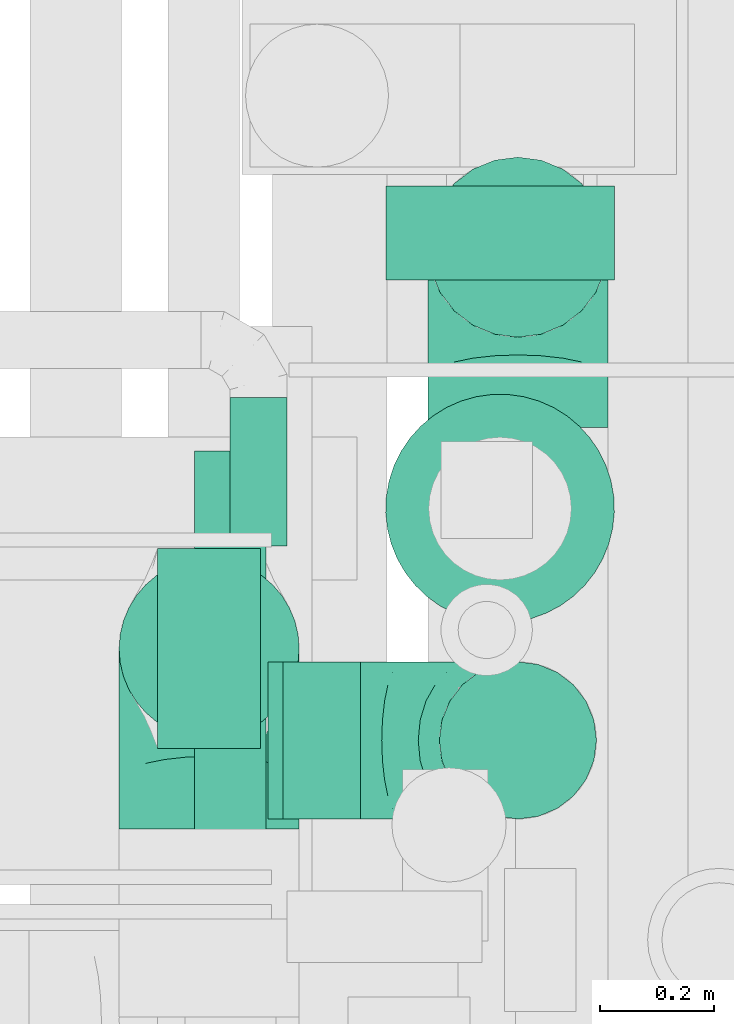
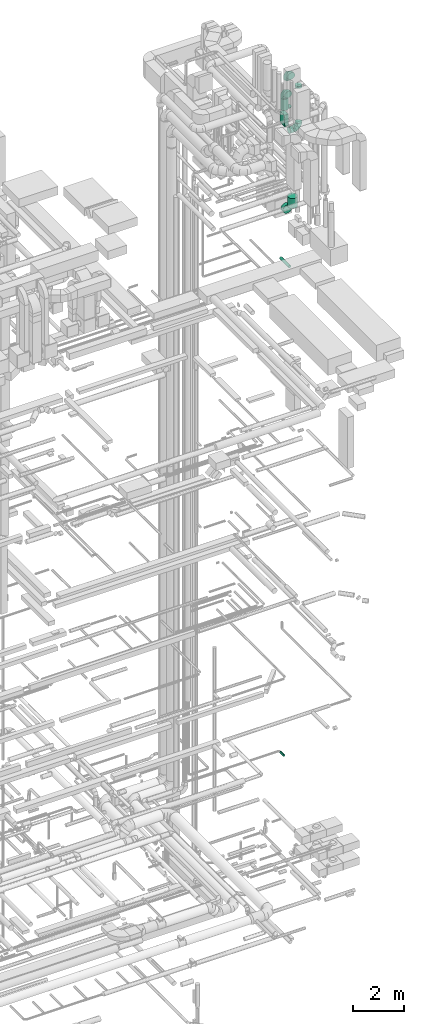
# One storey, part 308 of 337: 7 flow fittings, 7 flow segments.
"""IFC2X3 building model written with IfcOpenShell, lengths in millimetres."""

from ifc_helpers import new_model, entity, si_unit, converted_unit, derived_unit, direction, frame, origin, origin_2d_with_axis, place, context, subcontext, project, spatial, rectangle, circle, extrude, faceted_brep, source, transform, mapped, material, type_object, type_shapes, element, save


model = new_model("IFC2X3")

# Units and contexts
model_context = context("Model", 3, precision=0.01, world=origin(), true_north=direction((6.12303176911189e-17, 1.0)))
body_context = subcontext(model_context, "Body", "Model", "MODEL_VIEW")
ifc_project = project(units=[si_unit("LENGTHUNIT", "METRE", prefix="MILLI"), si_unit("AREAUNIT", "SQUARE_METRE"), si_unit("VOLUMEUNIT", "CUBIC_METRE"), converted_unit("PLANEANGLEUNIT", "DEGREE", entity("IfcRatioMeasure", 0.0174532925199433), si_unit("PLANEANGLEUNIT", "RADIAN"), dimensions=[0, 0, 0, 0, 0, 0, 0]), si_unit("MASSUNIT", "GRAM", prefix="KILO"), derived_unit("MASSDENSITYUNIT", [(si_unit("MASSUNIT", "GRAM", prefix="KILO"), 1), (si_unit("LENGTHUNIT", "METRE"), -3)]), derived_unit("MOMENTOFINERTIAUNIT", [(si_unit("LENGTHUNIT", "METRE"), 4)]), si_unit("TIMEUNIT", "SECOND"), si_unit("FREQUENCYUNIT", "HERTZ"), si_unit("THERMODYNAMICTEMPERATUREUNIT", "DEGREE_CELSIUS"), derived_unit("THERMALTRANSMITTANCEUNIT", [(si_unit("MASSUNIT", "GRAM", prefix="KILO"), 1), (si_unit("THERMODYNAMICTEMPERATUREUNIT", "KELVIN"), -1), (si_unit("TIMEUNIT", "SECOND"), -3)]), derived_unit("VOLUMETRICFLOWRATEUNIT", [(si_unit("LENGTHUNIT", "METRE"), 3), (si_unit("TIMEUNIT", "SECOND"), -1)]), derived_unit("MASSFLOWRATEUNIT", [(si_unit("MASSUNIT", "GRAM", prefix="KILO"), 1), (si_unit("TIMEUNIT", "SECOND"), -1)]), derived_unit("ROTATIONALFREQUENCYUNIT", [(si_unit("TIMEUNIT", "SECOND"), -1)]), si_unit("ELECTRICCURRENTUNIT", "AMPERE"), si_unit("ELECTRICVOLTAGEUNIT", "VOLT"), si_unit("POWERUNIT", "WATT"), si_unit("FORCEUNIT", "NEWTON", prefix="KILO"), si_unit("ILLUMINANCEUNIT", "LUX"), si_unit("LUMINOUSFLUXUNIT", "LUMEN"), si_unit("LUMINOUSINTENSITYUNIT", "CANDELA"), derived_unit("USERDEFINED", [(si_unit("MASSUNIT", "GRAM", prefix="KILO"), -1), (si_unit("LENGTHUNIT", "METRE"), -2), (si_unit("TIMEUNIT", "SECOND"), 3), (si_unit("LUMINOUSFLUXUNIT", "LUMEN"), 1)]), derived_unit("LINEARVELOCITYUNIT", [(si_unit("LENGTHUNIT", "METRE"), 1), (si_unit("TIMEUNIT", "SECOND"), -1)]), si_unit("PRESSUREUNIT", "PASCAL"), derived_unit("USERDEFINED", [(si_unit("LENGTHUNIT", "METRE"), -2), (si_unit("MASSUNIT", "GRAM", prefix="KILO"), 1), (si_unit("TIMEUNIT", "SECOND"), -2)]), derived_unit("LINEARFORCEUNIT", [(si_unit("MASSUNIT", "GRAM", prefix="KILO"), 1), (si_unit("LENGTHUNIT", "METRE"), 1), (si_unit("TIMEUNIT", "SECOND"), -2), (si_unit("LENGTHUNIT", "METRE"), -1)]), derived_unit("PLANARFORCEUNIT", [(si_unit("MASSUNIT", "GRAM", prefix="KILO"), 1), (si_unit("LENGTHUNIT", "METRE"), 1), (si_unit("TIMEUNIT", "SECOND"), -2), (si_unit("LENGTHUNIT", "METRE"), -2)])], contexts=[model_context])

# Site, building, storey
site_placement = place(None, origin())
site = spatial("IfcSite", under=ifc_project, at=site_placement, CompositionType="ELEMENT")
building_placement = place(site_placement, origin())
building = spatial("IfcBuilding", under=site, at=building_placement, CompositionType="ELEMENT")
storey_placement = place(building_placement, origin())
storey = spatial("IfcBuildingStorey", under=building, at=storey_placement, CompositionType="ELEMENT", Elevation=0.0)

# Flow segments
duct_segment_type_1 = type_object("IfcDuctSegmentType", PredefinedType="NOTDEFINED")
flow_segment_1_placement = place(storey_placement, frame((72113.11, 10840.65, 33495.0)))
element("IfcFlowSegment", 1, at=flow_segment_1_placement, inside=storey, type_object=duct_segment_type_1, context=body_context, shape_type="SweptSolid", body=[
    extrude(rectangle(XDim=179.999999999994, YDim=350.000000000001, at=origin_2d_with_axis()), frame((90.0, 175.0, 0.0)), (0.0, 0.0, 1.0), 524.999999999989),
])
duct_segment_type_2 = type_object("IfcDuctSegmentType", PredefinedType="NOTDEFINED")
flow_segment_2_placement = place(storey_placement, frame((72044.01, 10856.55, 34220.0)))
element("IfcFlowSegment", 2, at=flow_segment_2_placement, inside=storey, type_object=duct_segment_type_2, context=body_context, shape_type="SweptSolid", body=[
    extrude(circle(Radius=157.5, at=origin_2d_with_axis()), frame((159.1, 159.1, 0.0), z_axis=(0.0, 0.0, 1.0), x_axis=(-1.0, 0.0, 0.0)), (0.0, 0.0, 1.0), 535.000000000008),
])
flow_segment_3_placement = place(storey_placement, frame((72331.99, 10716.05, 33095.97)))
element("IfcFlowSegment", 3, at=flow_segment_3_placement, inside=storey, type_object=duct_segment_type_2, context=body_context, shape_type="SweptSolid", body=[
    extrude(circle(Radius=137.5, at=origin_2d_with_axis()), frame((0.0, 139.1, 139.1), z_axis=(1.0, 0.0, 0.0), x_axis=(0.0, 1.0, 0.0)), (0.0, 0.0, 1.0), 136.120315571918),
])
flow_segment_4_placement = place(storey_placement, frame((72510.22, 11058.98, 29250.0)))
element("IfcFlowSegment", 4, at=flow_segment_4_placement, inside=storey, type_object=duct_segment_type_2, context=body_context, shape_type="SweptSolid", body=[
    extrude(circle(Radius=200.0, at=origin_2d_with_axis()), frame((201.6, 201.6, 0.0), z_axis=(0.0, 0.0, 1.0), x_axis=(0.0, -1.0, 0.0)), (0.0, 0.0, 1.0), 480.000000000008),
])
flow_segment_5_placement = place(storey_placement, frame((72510.22, 11660.58, 28648.4)))
element("IfcFlowSegment", 5, at=flow_segment_5_placement, inside=storey, type_object=duct_segment_type_2, context=body_context, shape_type="SweptSolid", body=[
    extrude(circle(Radius=200.0, at=origin_2d_with_axis()), frame((201.6, 0.0, 201.6), z_axis=(0.0, 1.0, 0.0), x_axis=(1.0, 0.0, 0.0)), (0.0, 0.0, 1.0), 164.499999999999),
])
flow_segment_6_placement = place(storey_placement, frame((72175.92, 10675.99, 26795.9)))
element("IfcFlowSegment", 6, at=flow_segment_6_placement, inside=storey, type_object=duct_segment_type_2, context=body_context, shape_type="SweptSolid", body=[
    extrude(circle(Radius=62.5, at=origin_2d_with_axis()), frame((64.1, 0.0, 64.1), z_axis=(0.0, 1.0, 0.0), x_axis=(1.0, 0.0, 0.0)), (0.0, 0.0, 1.0), 684.999999999996),
])
flow_segment_7_placement = place(storey_placement, frame((72237.6, 11195.25, 3168.4)))
element("IfcFlowSegment", 7, at=flow_segment_7_placement, inside=storey, type_object=duct_segment_type_2, context=body_context, shape_type="SweptSolid", body=[
    extrude(circle(Radius=50.0, at=origin_2d_with_axis()), frame((51.6, 0.0, 51.6), z_axis=(0.0, 1.0, 0.0), x_axis=(-1.0, 0.0, 0.0)), (0.0, 0.0, 1.0), 260.000000000006),
])

# Flow fittings
ifc_material = material()
duct_fitting_type_1 = type_object("IfcDuctFittingType", PredefinedType="NOTDEFINED", material=ifc_material)
shared_shape_1 = source(origin(), body_context, "Body", "SweptSolid", [
    extrude(rectangle(XDim=180.0, YDim=26.096, at=origin_2d_with_axis()), frame((6.95, 0.0, -175.0), z_axis=(0.0, 0.0, 1.0), x_axis=(0.0, -1.0, 0.0)), (0.0, 0.0, 1.0), 350.0),
])
type_shapes(duct_fitting_type_1, [shared_shape_1])
flow_fitting_1_placement = place(storey_placement, frame((72203.11, 11015.65, 33475.0), z_axis=(0.0, 1.0, 0.0), x_axis=(0.0, 0.0, 1.0)))
element("IfcFlowFitting", 8, at=flow_fitting_1_placement, inside=storey, type_object=duct_fitting_type_1, material=ifc_material, context=body_context, shape_type="MappedRepresentation", body=[
    mapped(shared_shape_1, transform((0.0, 0.0, 0.0), scale=1.0)),
])
duct_fitting_type_2 = type_object("IfcDuctFittingType", PredefinedType="NOTDEFINED", material=ifc_material)
shared_shape_2 = source(origin(), body_context, "Body", "Brep", [
    faceted_brep([(-315.0, 0.0, -157.5), (-315.0, -40.76, -152.13), (-315.0, -78.75, -136.4), (-315.0, -111.37, -111.37), (-315.0, -136.4, -78.75), (-315.0, -152.13, -40.76), (-315.0, -157.5, 0.0), (-315.0, -152.13, 40.76), (-315.0, -136.4, 78.75), (-315.0, -111.37, 111.37), (-315.0, -78.75, 136.4), (-315.0, -40.76, 152.13), (-315.0, 0.0, 157.5), (-315.0, 40.76, 152.13), (-315.0, 78.75, 136.4), (-315.0, 111.37, 111.37), (-315.0, 136.4, 78.75), (-315.0, 152.13, 40.76), (-315.0, 157.5, 0.0), (-315.0, 152.13, -40.76), (-315.0, 136.4, -78.75), (-315.0, 111.37, -111.37), (-315.0, 78.75, -136.4), (-315.0, 40.76, -152.13), (-241.52, 40.76, 152.13), (-251.7, 78.75, 136.4), (-230.6, 0.0, 157.5), (-260.44, 111.37, 111.37), (-271.36, 152.13, 40.76), (-272.8, 157.5, 0.0), (-267.14, 136.4, 78.75), (-267.14, 136.4, -78.75), (-260.44, 111.37, -111.37), (-271.36, 152.13, -40.76), (-241.52, 40.76, -152.13), (-230.6, 0.0, -157.5), (-251.7, 78.75, -136.4), (-219.67, -40.76, -152.13), (-209.5, -78.75, -136.4), (-200.75, -111.37, -111.37), (-194.05, -136.4, -78.75), (-189.83, -152.13, -40.76), (-188.39, -157.5, 0.0), (-189.83, -152.13, 40.76), (-194.05, -136.4, 78.75), (-200.75, -111.37, 111.37), (-209.5, -78.75, 136.4), (-219.67, -40.76, 152.13), (-114.25, 114.25, 152.13), (-142.05, 142.05, 136.4), (-84.4, 84.4, 157.5), (-165.93, 165.93, 111.37), (-184.25, 184.25, 78.75), (-195.77, 195.77, 40.76), (-199.7, 199.7, 0.0), (-195.77, 195.77, -40.76), (-184.25, 184.25, -78.75), (-165.93, 165.93, -111.37), (-114.25, 114.25, -152.13), (-84.4, 84.4, -157.5), (-142.05, 142.05, -136.4), (-54.56, 54.56, -152.13), (-26.75, 26.75, -136.4), (-2.88, 2.88, -111.37), (15.45, -15.45, -78.75), (26.97, -26.97, -40.76), (30.89, -30.89, 0.0), (26.97, -26.97, 40.76), (15.45, -15.45, 78.75), (-2.88, 2.88, 111.37), (-26.75, 26.75, 136.4), (-54.56, 54.56, 152.13), (-40.76, 241.52, 152.13), (-78.75, 251.7, 136.4), (0.0, 230.6, 157.5), (-111.37, 260.44, 111.37), (-136.4, 267.14, 78.75), (-152.13, 271.36, 40.76), (-157.5, 272.8, 0.0), (-152.13, 271.36, -40.76), (-136.4, 267.14, -78.75), (-111.37, 260.44, -111.37), (-40.76, 241.52, -152.13), (0.0, 230.6, -157.5), (-78.75, 251.7, -136.4), (40.76, 219.67, -152.13), (78.75, 209.5, -136.4), (111.37, 200.75, -111.37), (136.4, 194.05, -78.75), (152.13, 189.83, -40.76), (157.5, 188.39, 0.0), (152.13, 189.83, 40.76), (136.4, 194.05, 78.75), (111.37, 200.75, 111.37), (78.75, 209.5, 136.4), (40.76, 219.67, 152.13), (-40.76, 315.0, -152.13), (-78.75, 315.0, -136.4), (-111.37, 315.0, -111.37), (-136.4, 315.0, -78.75), (-152.13, 315.0, -40.76), (-157.5, 315.0, 0.0), (-152.13, 315.0, 40.76), (-136.4, 315.0, 78.75), (-111.37, 315.0, 111.37), (-78.75, 315.0, 136.4), (-40.76, 315.0, 152.13), (0.0, 315.0, 157.5), (40.76, 315.0, 152.13), (78.75, 315.0, 136.4), (111.37, 315.0, 111.37), (136.4, 315.0, 78.75), (152.13, 315.0, 40.76), (157.5, 315.0, 0.0), (152.13, 315.0, -40.76), (136.4, 315.0, -78.75), (111.37, 315.0, -111.37), (78.75, 315.0, -136.4), (40.76, 315.0, -152.13), (0.0, 315.0, -157.5)], [[[0, 1, 2, 3, 4, 5, 6, 7, 8, 9, 10, 11, 12, 13, 14, 15, 16, 17, 18, 19, 20, 21, 22, 23]], [[24, 25, 14, 13]], [[26, 24, 13, 12]], [[14, 25, 27, 15]], [[28, 29, 18, 17]], [[30, 28, 17, 16]], [[15, 27, 30, 16]], [[20, 31, 32, 21]], [[33, 31, 20, 19]], [[18, 29, 33, 19]], [[34, 35, 0, 23]], [[36, 34, 23, 22]], [[32, 36, 22, 21]], [[1, 0, 35, 37]], [[2, 1, 37, 38]], [[38, 39, 3, 2]], [[5, 4, 40, 41]], [[6, 5, 41, 42]], [[39, 40, 4, 3]], [[6, 42, 43, 7]], [[7, 43, 44, 8]], [[8, 44, 45, 9]], [[9, 45, 46, 10]], [[10, 46, 47, 11]], [[26, 12, 11, 47]], [[48, 49, 25, 24]], [[50, 48, 24, 26]], [[27, 25, 49, 51]], [[52, 53, 28, 30]], [[51, 52, 30, 27]], [[29, 28, 53, 54]], [[55, 56, 31, 33]], [[54, 55, 33, 29]], [[32, 31, 56, 57]], [[58, 59, 35, 34]], [[60, 58, 34, 36]], [[57, 60, 36, 32]], [[37, 35, 59, 61]], [[38, 37, 61, 62]], [[39, 38, 62, 63]], [[41, 40, 64, 65]], [[42, 41, 65, 66]], [[63, 64, 40, 39]], [[43, 42, 66, 67]], [[44, 43, 67, 68]], [[68, 69, 45, 44]], [[46, 45, 69, 70]], [[47, 46, 70, 71]], [[26, 47, 71, 50]], [[72, 73, 49, 48]], [[74, 72, 48, 50]], [[51, 49, 73, 75]], [[76, 77, 53, 52]], [[75, 76, 52, 51]], [[54, 53, 77, 78]], [[79, 80, 56, 55]], [[78, 79, 55, 54]], [[57, 56, 80, 81]], [[82, 83, 59, 58]], [[84, 82, 58, 60]], [[81, 84, 60, 57]], [[61, 59, 83, 85]], [[62, 61, 85, 86]], [[63, 62, 86, 87]], [[65, 64, 88, 89]], [[66, 65, 89, 90]], [[87, 88, 64, 63]], [[67, 66, 90, 91]], [[68, 67, 91, 92]], [[92, 93, 69, 68]], [[70, 69, 93, 94]], [[71, 70, 94, 95]], [[50, 71, 95, 74]], [[96, 97, 98, 99, 100, 101, 102, 103, 104, 105, 106, 107, 108, 109, 110, 111, 112, 113, 114, 115, 116, 117, 118, 119]], [[106, 105, 73, 72]], [[107, 106, 72, 74]], [[75, 73, 105, 104]], [[77, 76, 103, 102]], [[78, 77, 102, 101]], [[104, 103, 76, 75]], [[78, 101, 100, 79]], [[79, 100, 99, 80]], [[98, 81, 80, 99]], [[84, 97, 96, 82]], [[82, 96, 119, 83]], [[97, 84, 81, 98]], [[83, 119, 118, 85]], [[85, 118, 117, 86]], [[116, 87, 86, 117]], [[88, 115, 114, 89]], [[89, 114, 113, 90]], [[115, 88, 87, 116]], [[91, 90, 113, 112]], [[92, 91, 112, 111]], [[111, 110, 93, 92]], [[95, 94, 109, 108]], [[74, 95, 108, 107]], [[110, 109, 94, 93]]]),
])
type_shapes(duct_fitting_type_2, [shared_shape_2])
for number, where, z_axis, x_axis in (
    (9, (72203.11, 11015.65, 35070.0), (1.0, 0.0, 0.0), (0.0, 0.0, 1.0)),
    (10, (72743.11, 11717.65, 35340.0), (-1.0, 0.0, 0.0), (0.0, 1.0, 0.0)),
):
    element("IfcFlowFitting", number, at=place(storey_placement, frame(where, z_axis=z_axis, x_axis=x_axis)), inside=storey, type_object=duct_fitting_type_2, material=ifc_material, context=body_context, shape_type="MappedRepresentation", body=[
        mapped(shared_shape_2, transform((0.0, 0.0, 0.0), scale=1.0)),
    ])
duct_fitting_type_3 = type_object("IfcDuctFittingType", PredefinedType="NOTDEFINED", material=ifc_material)
shared_shape_3 = source(origin(), body_context, "Body", "Brep", [
    faceted_brep([(20.0, 0.0, -157.5), (20.0, 40.76, -152.13), (20.0, 78.75, -136.4), (20.0, 111.37, -111.37), (20.0, 136.4, -78.75), (20.0, 152.13, -40.76), (20.0, 157.5, 0.0), (20.0, 152.13, 40.76), (20.0, 136.4, 78.75), (20.0, 111.37, 111.37), (20.0, 78.75, 136.4), (20.0, 40.76, 152.13), (20.0, 0.0, 157.5), (20.0, -40.76, 152.13), (20.0, -78.75, 136.4), (20.0, -111.37, 111.37), (20.0, -136.4, 78.75), (20.0, -152.13, 40.76), (20.0, -157.5, 0.0), (20.0, -152.13, -40.76), (20.0, -136.4, -78.75), (20.0, -111.37, -111.37), (20.0, -78.75, -136.4), (20.0, -40.76, -152.13), (0.0, 0.0, 157.5), (-6.1, 0.0, 157.5), (-6.1, -40.76, 152.13), (0.0, -40.76, 152.13), (-6.1, -78.75, 136.4), (0.0, -78.75, 136.4), (0.0, -111.37, 111.37), (-6.1, -111.37, 111.37), (0.0, -136.4, 78.75), (-6.1, -136.4, 78.75), (-6.1, -152.13, 40.76), (0.0, -152.13, 40.76), (-6.1, -157.5, 0.0), (0.0, -157.5, 0.0), (-6.1, -152.13, -40.76), (0.0, -152.13, -40.76), (-6.1, -136.4, -78.75), (0.0, -136.4, -78.75), (0.0, -111.37, -111.37), (-6.1, -111.37, -111.37), (0.0, 0.0, -157.5), (0.0, -40.76, -152.13), (-6.1, -40.76, -152.13), (-6.1, 0.0, -157.5), (0.0, -78.75, -136.4), (-6.1, -78.75, -136.4), (-6.1, 40.76, -152.13), (0.0, 40.76, -152.13), (-6.1, 78.75, -136.4), (0.0, 78.75, -136.4), (0.0, 111.37, -111.37), (-6.1, 111.37, -111.37), (0.0, 136.4, -78.75), (-6.1, 136.4, -78.75), (-6.1, 152.13, -40.76), (0.0, 152.13, -40.76), (-6.1, 157.5, 0.0), (0.0, 157.5, 0.0), (-6.1, 152.13, 40.76), (0.0, 152.13, 40.76), (-6.1, 136.4, 78.75), (0.0, 136.4, 78.75), (0.0, 111.37, 111.37), (-6.1, 111.37, 111.37), (0.0, 78.75, 136.4), (-6.1, 78.75, 136.4), (-6.1, 40.76, 152.13), (0.0, 40.76, 152.13)], [[[0, 1, 2, 3, 4, 5, 6, 7, 8, 9, 10, 11, 12, 13, 14, 15, 16, 17, 18, 19, 20, 21, 22, 23]], [[13, 12, 24, 25, 26, 27]], [[14, 13, 27, 26, 28, 29]], [[30, 15, 14, 29, 28, 31]], [[17, 16, 32, 33, 34, 35]], [[18, 17, 35, 34, 36, 37]], [[32, 16, 15, 30, 31, 33]], [[19, 18, 37, 36, 38, 39]], [[20, 19, 39, 38, 40, 41]], [[42, 21, 20, 41, 40, 43]], [[44, 0, 23, 45, 46, 47]], [[48, 49, 46, 45, 23, 22]], [[22, 21, 42, 43, 49, 48]], [[1, 0, 44, 47, 50, 51]], [[2, 1, 51, 50, 52, 53]], [[54, 3, 2, 53, 52, 55]], [[5, 4, 56, 57, 58, 59]], [[6, 5, 59, 58, 60, 61]], [[56, 4, 3, 54, 55, 57]], [[7, 6, 61, 60, 62, 63]], [[8, 7, 63, 62, 64, 65]], [[66, 9, 8, 65, 64, 67]], [[11, 10, 68, 69, 70, 71]], [[12, 11, 71, 70, 25, 24]], [[68, 10, 9, 66, 67, 69]], [[46, 49, 43, 40, 38, 36, 34, 33, 31, 28, 26, 25, 70, 69, 67, 64, 62, 60, 58, 57, 55, 52, 50, 47]]]),
])
type_shapes(duct_fitting_type_3, [shared_shape_3])
flow_fitting_2_placement = place(storey_placement, frame((72743.11, 11717.65, 33696.26), z_axis=(0.0, 1.0, 0.0), x_axis=(0.0, 0.0, 1.0)))
element("IfcFlowFitting", 11, at=flow_fitting_2_placement, inside=storey, type_object=duct_fitting_type_3, material=ifc_material, context=body_context, shape_type="MappedRepresentation", body=[
    mapped(shared_shape_3, transform((0.0, 0.0, 0.0), scale=1.0)),
])
duct_fitting_type_4 = type_object("IfcDuctFittingType", PredefinedType="NOTDEFINED", material=ifc_material)
shared_shape_4 = source(origin(), body_context, "Body", "Brep", [
    faceted_brep([(20.0, 0.0, -137.5), (20.0, 35.59, -132.81), (20.0, 68.75, -119.08), (20.0, 97.23, -97.23), (20.0, 119.08, -68.75), (20.0, 132.81, -35.59), (20.0, 137.5, 0.0), (20.0, 132.81, 35.59), (20.0, 119.08, 68.75), (20.0, 97.23, 97.23), (20.0, 68.75, 119.08), (20.0, 35.59, 132.81), (20.0, 0.0, 137.5), (20.0, -35.59, 132.81), (20.0, -68.75, 119.08), (20.0, -97.23, 97.23), (20.0, -119.08, 68.75), (20.0, -132.81, 35.59), (20.0, -137.5, 0.0), (20.0, -132.81, -35.59), (20.0, -119.08, -68.75), (20.0, -97.23, -97.23), (20.0, -68.75, -119.08), (20.0, -35.59, -132.81), (0.0, 0.0, 137.5), (-86.78, 0.0, 137.5), (-86.78, -35.59, 132.81), (0.0, -35.59, 132.81), (-86.78, -68.75, 119.08), (0.0, -68.75, 119.08), (0.0, -97.23, 97.23), (-86.78, -97.23, 97.23), (0.0, -119.08, 68.75), (-86.78, -119.08, 68.75), (-86.78, -132.81, 35.59), (0.0, -132.81, 35.59), (-86.78, -137.5, 0.0), (0.0, -137.5, 0.0), (-86.78, -132.81, -35.59), (0.0, -132.81, -35.59), (-86.78, -119.08, -68.75), (0.0, -119.08, -68.75), (0.0, -97.23, -97.23), (-86.78, -97.23, -97.23), (0.0, -68.75, -119.08), (-86.78, -68.75, -119.08), (-86.78, -35.59, -132.81), (0.0, -35.59, -132.81), (-86.78, 0.0, -137.5), (0.0, 0.0, -137.5), (-86.78, 35.59, -132.81), (0.0, 35.59, -132.81), (-86.78, 68.75, -119.08), (0.0, 68.75, -119.08), (0.0, 97.23, -97.23), (-86.78, 97.23, -97.23), (0.0, 119.08, -68.75), (-86.78, 119.08, -68.75), (-86.78, 132.81, -35.59), (0.0, 132.81, -35.59), (-86.78, 137.5, 0.0), (0.0, 137.5, 0.0), (-86.78, 132.81, 35.59), (0.0, 132.81, 35.59), (-86.78, 119.08, 68.75), (0.0, 119.08, 68.75), (0.0, 97.23, 97.23), (-86.78, 97.23, 97.23), (0.0, 68.75, 119.08), (-86.78, 68.75, 119.08), (-86.78, 35.59, 132.81), (0.0, 35.59, 132.81)], [[[0, 1, 2, 3, 4, 5, 6, 7, 8, 9, 10, 11, 12, 13, 14, 15, 16, 17, 18, 19, 20, 21, 22, 23]], [[13, 12, 24, 25, 26, 27]], [[14, 13, 27, 26, 28, 29]], [[30, 15, 14, 29, 28, 31]], [[17, 16, 32, 33, 34, 35]], [[18, 17, 35, 34, 36, 37]], [[32, 16, 15, 30, 31, 33]], [[19, 18, 37, 36, 38, 39]], [[20, 19, 39, 38, 40, 41]], [[42, 21, 20, 41, 40, 43]], [[23, 22, 44, 45, 46, 47]], [[0, 23, 47, 46, 48, 49]], [[44, 22, 21, 42, 43, 45]], [[1, 0, 49, 48, 50, 51]], [[2, 1, 51, 50, 52, 53]], [[54, 3, 2, 53, 52, 55]], [[5, 4, 56, 57, 58, 59]], [[6, 5, 59, 58, 60, 61]], [[56, 4, 3, 54, 55, 57]], [[7, 6, 61, 60, 62, 63]], [[8, 7, 63, 62, 64, 65]], [[66, 9, 8, 65, 64, 67]], [[11, 10, 68, 69, 70, 71]], [[12, 11, 71, 70, 25, 24]], [[68, 10, 9, 66, 67, 69]], [[46, 45, 43, 40, 38, 36, 34, 33, 31, 28, 26, 25, 70, 69, 67, 64, 62, 60, 58, 57, 55, 52, 50, 48]]]),
])
type_shapes(duct_fitting_type_4, [shared_shape_4])
flow_fitting_3_placement = place(storey_placement, frame((72743.11, 10855.15, 35182.5), z_axis=(0.0, 1.0, 0.0), x_axis=(0.0, 0.0, -1.0)))
element("IfcFlowFitting", 12, at=flow_fitting_3_placement, inside=storey, type_object=duct_fitting_type_4, material=ifc_material, context=body_context, shape_type="MappedRepresentation", body=[
    mapped(shared_shape_4, transform((0.0, 0.0, 0.0), scale=1.0)),
])
duct_fitting_type_5 = type_object("IfcDuctFittingType", PredefinedType="NOTDEFINED", material=ifc_material)
shared_shape_5 = source(origin(), body_context, "Body", "Brep", [
    faceted_brep([(-275.0, 0.0, -137.5), (-275.0, -35.59, -132.81), (-275.0, -68.75, -119.08), (-275.0, -97.23, -97.23), (-275.0, -119.08, -68.75), (-275.0, -132.81, -35.59), (-275.0, -137.5, 0.0), (-275.0, -132.81, 35.59), (-275.0, -119.08, 68.75), (-275.0, -97.23, 97.23), (-275.0, -68.75, 119.08), (-275.0, -35.59, 132.81), (-275.0, 0.0, 137.5), (-275.0, 35.59, 132.81), (-275.0, 68.75, 119.08), (-275.0, 97.23, 97.23), (-275.0, 119.08, 68.75), (-275.0, 132.81, 35.59), (-275.0, 137.5, 0.0), (-275.0, 132.81, -35.59), (-275.0, 119.08, -68.75), (-275.0, 97.23, -97.23), (-275.0, 68.75, -119.08), (-275.0, 35.59, -132.81), (-210.85, 35.59, 132.81), (-219.74, 68.75, 119.08), (-201.31, 0.0, 137.5), (-227.37, 97.23, 97.23), (-236.9, 132.81, 35.59), (-238.16, 137.5, 0.0), (-233.22, 119.08, 68.75), (-233.22, 119.08, -68.75), (-227.37, 97.23, -97.23), (-236.9, 132.81, -35.59), (-210.85, 35.59, -132.81), (-201.31, 0.0, -137.5), (-219.74, 68.75, -119.08), (-191.78, -35.59, -132.81), (-182.89, -68.75, -119.08), (-175.26, -97.23, -97.23), (-169.41, -119.08, -68.75), (-165.73, -132.81, -35.59), (-164.47, -137.5, 0.0), (-165.73, -132.81, 35.59), (-169.41, -119.08, 68.75), (-175.26, -97.23, 97.23), (-182.89, -68.75, 119.08), (-191.78, -35.59, 132.81), (-99.74, 99.74, 132.81), (-124.01, 124.01, 119.08), (-73.69, 73.69, 137.5), (-144.86, 144.86, 97.23), (-160.86, 160.86, 68.75), (-170.91, 170.91, 35.59), (-174.34, 174.34, 0.0), (-170.91, 170.91, -35.59), (-160.86, 160.86, -68.75), (-144.86, 144.86, -97.23), (-99.74, 99.74, -132.81), (-73.69, 73.69, -137.5), (-124.01, 124.01, -119.08), (-47.63, 47.63, -132.81), (-23.36, 23.36, -119.08), (-2.51, 2.51, -97.23), (13.49, -13.49, -68.75), (23.54, -23.54, -35.59), (26.97, -26.97, 0.0), (23.54, -23.54, 35.59), (13.49, -13.49, 68.75), (-2.51, 2.51, 97.23), (-23.36, 23.36, 119.08), (-47.63, 47.63, 132.81), (-35.59, 210.85, 132.81), (-68.75, 219.74, 119.08), (0.0, 201.31, 137.5), (-97.23, 227.37, 97.23), (-119.08, 233.22, 68.75), (-132.81, 236.9, 35.59), (-137.5, 238.16, 0.0), (-132.81, 236.9, -35.59), (-119.08, 233.22, -68.75), (-97.23, 227.37, -97.23), (-35.59, 210.85, -132.81), (0.0, 201.31, -137.5), (-68.75, 219.74, -119.08), (35.59, 191.78, -132.81), (68.75, 182.89, -119.08), (97.23, 175.26, -97.23), (119.08, 169.41, -68.75), (132.81, 165.73, -35.59), (137.5, 164.47, 0.0), (132.81, 165.73, 35.59), (119.08, 169.41, 68.75), (97.23, 175.26, 97.23), (68.75, 182.89, 119.08), (35.59, 191.78, 132.81), (-35.59, 275.0, -132.81), (-68.75, 275.0, -119.08), (-97.23, 275.0, -97.23), (-119.08, 275.0, -68.75), (-132.81, 275.0, -35.59), (-137.5, 275.0, 0.0), (-132.81, 275.0, 35.59), (-119.08, 275.0, 68.75), (-97.23, 275.0, 97.23), (-68.75, 275.0, 119.08), (-35.59, 275.0, 132.81), (0.0, 275.0, 137.5), (35.59, 275.0, 132.81), (68.75, 275.0, 119.08), (97.23, 275.0, 97.23), (119.08, 275.0, 68.75), (132.81, 275.0, 35.59), (137.5, 275.0, 0.0), (132.81, 275.0, -35.59), (119.08, 275.0, -68.75), (97.23, 275.0, -97.23), (68.75, 275.0, -119.08), (35.59, 275.0, -132.81), (0.0, 275.0, -137.5)], [[[0, 1, 2, 3, 4, 5, 6, 7, 8, 9, 10, 11, 12, 13, 14, 15, 16, 17, 18, 19, 20, 21, 22, 23]], [[24, 25, 14, 13]], [[26, 24, 13, 12]], [[14, 25, 27, 15]], [[28, 29, 18, 17]], [[30, 28, 17, 16]], [[15, 27, 30, 16]], [[20, 31, 32, 21]], [[33, 31, 20, 19]], [[18, 29, 33, 19]], [[34, 35, 0, 23]], [[36, 34, 23, 22]], [[32, 36, 22, 21]], [[1, 0, 35, 37]], [[2, 1, 37, 38]], [[38, 39, 3, 2]], [[5, 4, 40, 41]], [[6, 5, 41, 42]], [[39, 40, 4, 3]], [[6, 42, 43, 7]], [[7, 43, 44, 8]], [[8, 44, 45, 9]], [[9, 45, 46, 10]], [[10, 46, 47, 11]], [[26, 12, 11, 47]], [[48, 49, 25, 24]], [[50, 48, 24, 26]], [[27, 25, 49, 51]], [[52, 53, 28, 30]], [[51, 52, 30, 27]], [[29, 28, 53, 54]], [[55, 56, 31, 33]], [[54, 55, 33, 29]], [[32, 31, 56, 57]], [[58, 59, 35, 34]], [[60, 58, 34, 36]], [[57, 60, 36, 32]], [[37, 35, 59, 61]], [[38, 37, 61, 62]], [[39, 38, 62, 63]], [[41, 40, 64, 65]], [[42, 41, 65, 66]], [[63, 64, 40, 39]], [[43, 42, 66, 67]], [[44, 43, 67, 68]], [[68, 69, 45, 44]], [[46, 45, 69, 70]], [[47, 46, 70, 71]], [[26, 47, 71, 50]], [[72, 73, 49, 48]], [[74, 72, 48, 50]], [[51, 49, 73, 75]], [[76, 77, 53, 52]], [[75, 76, 52, 51]], [[54, 53, 77, 78]], [[79, 80, 56, 55]], [[78, 79, 55, 54]], [[57, 56, 80, 81]], [[82, 83, 59, 58]], [[84, 82, 58, 60]], [[81, 84, 60, 57]], [[61, 59, 83, 85]], [[62, 61, 85, 86]], [[63, 62, 86, 87]], [[65, 64, 88, 89]], [[66, 65, 89, 90]], [[87, 88, 64, 63]], [[67, 66, 90, 91]], [[68, 67, 91, 92]], [[92, 93, 69, 68]], [[70, 69, 93, 94]], [[71, 70, 94, 95]], [[50, 71, 95, 74]], [[96, 97, 98, 99, 100, 101, 102, 103, 104, 105, 106, 107, 108, 109, 110, 111, 112, 113, 114, 115, 116, 117, 118, 119]], [[72, 74, 107, 106]], [[73, 72, 106, 105]], [[75, 73, 105, 104]], [[77, 76, 103, 102]], [[78, 77, 102, 101]], [[104, 103, 76, 75]], [[78, 101, 100, 79]], [[79, 100, 99, 80]], [[98, 81, 80, 99]], [[84, 97, 96, 82]], [[82, 96, 119, 83]], [[97, 84, 81, 98]], [[83, 119, 118, 85]], [[85, 118, 117, 86]], [[116, 87, 86, 117]], [[88, 115, 114, 89]], [[89, 114, 113, 90]], [[115, 88, 87, 116]], [[91, 90, 113, 112]], [[92, 91, 112, 111]], [[111, 110, 93, 92]], [[95, 94, 109, 108]], [[74, 95, 108, 107]], [[110, 109, 94, 93]]]),
])
type_shapes(duct_fitting_type_5, [shared_shape_5])
flow_fitting_4_placement = place(storey_placement, frame((72743.11, 10855.15, 33235.07), z_axis=(0.0, 1.0, 0.0), x_axis=(0.0, 0.0, -1.0)))
element("IfcFlowFitting", 13, at=flow_fitting_4_placement, inside=storey, type_object=duct_fitting_type_5, material=ifc_material, context=body_context, shape_type="MappedRepresentation", body=[
    mapped(shared_shape_5, transform((0.0, 0.0, 0.0), scale=1.0)),
])
duct_fitting_type_6 = type_object("IfcDuctFittingType", PredefinedType="NOTDEFINED", material=ifc_material)
shared_shape_6 = source(origin(), body_context, "Body", "Brep", [
    faceted_brep([(20.0, 35.59, -132.81), (20.0, 68.75, -119.08), (20.0, 97.23, -97.23), (20.0, 119.08, -68.75), (20.0, 132.81, -35.59), (20.0, 137.5, 0.0), (20.0, 132.81, 35.59), (20.0, 119.08, 68.75), (20.0, 97.23, 97.23), (20.0, 68.75, 119.08), (20.0, 35.59, 132.81), (20.0, 0.0, 137.5), (20.0, -35.59, 132.81), (20.0, -68.75, 119.08), (20.0, -97.23, 97.23), (20.0, -119.08, 68.75), (20.0, -132.81, 35.59), (20.0, -137.5, 0.0), (20.0, -132.81, -35.59), (20.0, -119.08, -68.75), (20.0, -97.23, -97.23), (20.0, -68.75, -119.08), (20.0, -35.59, -132.81), (20.0, 0.0, -137.5), (0.0, 0.0, 137.5), (0.0, 35.59, 132.81), (-6.1, 35.59, 132.81), (-6.1, 0.0, 137.5), (0.0, 68.75, 119.08), (-6.1, 68.75, 119.08), (0.0, 97.23, 97.23), (-6.1, 97.23, 97.23), (0.0, 119.08, 68.75), (0.0, 132.81, 35.59), (-6.1, 132.81, 35.59), (-6.1, 119.08, 68.75), (0.0, 137.5, 0.0), (-6.1, 137.5, 0.0), (0.0, 132.81, -35.59), (-6.1, 132.81, -35.59), (0.0, 119.08, -68.75), (-6.1, 119.08, -68.75), (0.0, 97.23, -97.23), (-6.1, 97.23, -97.23), (0.0, 68.75, -119.08), (0.0, 35.59, -132.81), (-6.1, 35.59, -132.81), (-6.1, 68.75, -119.08), (0.0, 0.0, -137.5), (-6.1, 0.0, -137.5), (0.0, -35.59, -132.81), (-6.1, -35.59, -132.81), (0.0, -68.75, -119.08), (-6.1, -68.75, -119.08), (0.0, -97.23, -97.23), (-6.1, -97.23, -97.23), (0.0, -119.08, -68.75), (0.0, -132.81, -35.59), (-6.1, -132.81, -35.59), (-6.1, -119.08, -68.75), (0.0, -137.5, 0.0), (-6.1, -137.5, 0.0), (0.0, -132.81, 35.59), (-6.1, -132.81, 35.59), (0.0, -119.08, 68.75), (-6.1, -119.08, 68.75), (0.0, -97.23, 97.23), (-6.1, -97.23, 97.23), (0.0, -68.75, 119.08), (0.0, -35.59, 132.81), (-6.1, -35.59, 132.81), (-6.1, -68.75, 119.08)], [[[0, 1, 2, 3, 4, 5, 6, 7, 8, 9, 10, 11, 12, 13, 14, 15, 16, 17, 18, 19, 20, 21, 22, 23]], [[24, 11, 10, 25, 26, 27]], [[25, 10, 9, 28, 29, 26]], [[28, 9, 8, 30, 31, 29]], [[32, 7, 6, 33, 34, 35]], [[33, 6, 5, 36, 37, 34]], [[30, 8, 7, 32, 35, 31]], [[36, 5, 4, 38, 39, 37]], [[38, 4, 3, 40, 41, 39]], [[40, 3, 2, 42, 43, 41]], [[44, 1, 0, 45, 46, 47]], [[45, 0, 23, 48, 49, 46]], [[42, 2, 1, 44, 47, 43]], [[48, 23, 22, 50, 51, 49]], [[50, 22, 21, 52, 53, 51]], [[52, 21, 20, 54, 55, 53]], [[56, 19, 18, 57, 58, 59]], [[57, 18, 17, 60, 61, 58]], [[54, 20, 19, 56, 59, 55]], [[60, 17, 16, 62, 63, 61]], [[62, 16, 15, 64, 65, 63]], [[64, 15, 14, 66, 67, 65]], [[68, 13, 12, 69, 70, 71]], [[69, 12, 11, 24, 27, 70]], [[66, 14, 13, 68, 71, 67]], [[49, 51, 53, 55, 59, 58, 61, 63, 65, 67, 71, 70, 27, 26, 29, 31, 35, 34, 37, 39, 41, 43, 47, 46]]]),
])
type_shapes(duct_fitting_type_6, [shared_shape_6])
flow_fitting_5_placement = place(storey_placement, frame((72311.99, 10855.15, 33235.07), z_axis=(0.0, 0.0, -1.0), x_axis=(1.0, 0.0, 0.0)))
element("IfcFlowFitting", 14, at=flow_fitting_5_placement, inside=storey, type_object=duct_fitting_type_6, material=ifc_material, context=body_context, shape_type="MappedRepresentation", body=[
    mapped(shared_shape_6, transform((0.0, 0.0, 0.0), scale=1.0)),
])

save(model, "model.ifc")
